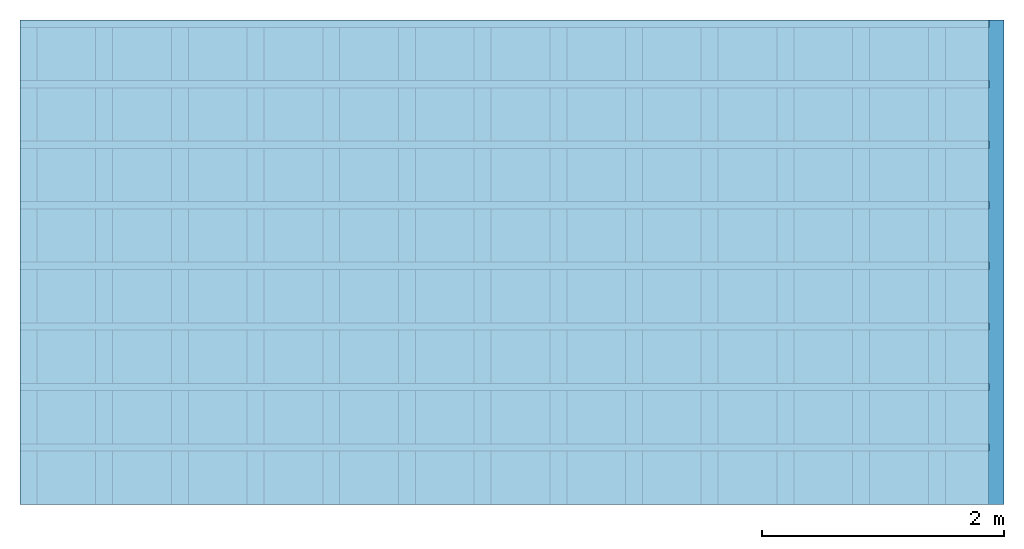
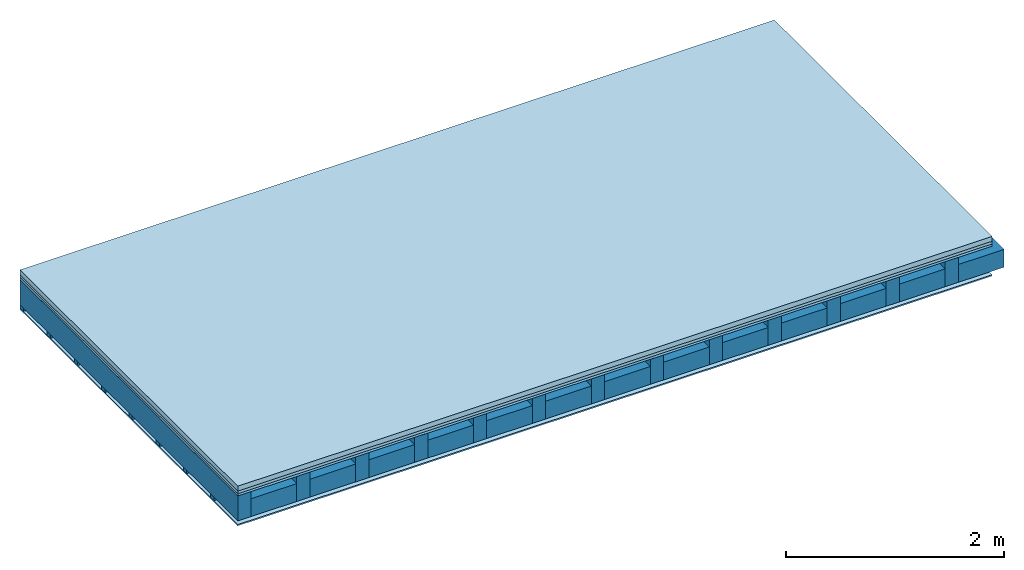
# One storey: 4 plates, 3 members, 1 element without a shape of its own.
"""IFC4 building model written with IfcOpenShell, lengths in metres."""

from ifc_helpers import new_model, si_unit, derived_unit, direction, frame, frame_2d, origin, origin_with_axes, place, context, project, spatial, rectangle, extrude, material, layer, layer_set, type_object, element, aggregate, save


model = new_model("IFC4")

# Units and contexts
plan_context = context("Plan", 3, precision=1e-05, world=origin(), true_north=direction((0.0, 1.0)))
model_context = context("Model", 3, precision=1e-05, world=origin(), true_north=direction((0.0, 1.0)))
ifc_project = project(units=[si_unit("LENGTHUNIT", "METRE"), derived_unit("SOUNDPRESSUREUNIT", [(si_unit("PRESSUREUNIT", "PASCAL", prefix="MICRO"), 0)]), si_unit("ENERGYUNIT", "JOULE", prefix="MEGA"), si_unit("MASSUNIT", "GRAM", prefix="KILO"), derived_unit("THERMALTRANSMITTANCEUNIT", [(si_unit("POWERUNIT", "WATT"), 1), (si_unit("AREAUNIT", "SQUARE_METRE"), -1), (si_unit("THERMODYNAMICTEMPERATUREUNIT", "KELVIN"), -1)]), derived_unit("AREADENSITYUNIT", [(si_unit("MASSUNIT", "GRAM", prefix="KILO"), 1), (si_unit("AREAUNIT", "SQUARE_METRE"), -1)]), derived_unit("USERDEFINED", [(si_unit("ENERGYUNIT", "JOULE", prefix="MEGA"), 1), (si_unit("AREAUNIT", "SQUARE_METRE"), -1)])], contexts=[plan_context, model_context])

# Site, building, storey
site = spatial("IfcSite", under=ifc_project)
building_placement = place(None, origin())
building = spatial("IfcBuilding", under=site, at=building_placement)
storey_placement = place(building_placement, origin())
storey = spatial("IfcBuildingStorey", under=building, at=storey_placement)

# Slab, members, plates
ifc_material_1 = material(Category="04.005")
ifc_layer_1 = layer(ifc_material_1, 0.055, Name="On-material")
ifc_material_2 = material()
ifc_layer_2 = layer(ifc_material_2, 0.03, Name="Impact sound insulation")
ifc_material_3 = material(Category="07.001")
ifc_layer_3 = layer(ifc_material_3, 0.025, Name="Sub-floor")
ifc_material_4 = material(Name="of the art")
ifc_layer_4 = layer(ifc_material_4, 0.0, Name="Bond")
ifc_layer_5 = layer(None, 0.28, Name="Supporting structure")
ifc_layer_6 = layer(ifc_material_4, 0.0, Name="Bond")
ifc_layer_7 = layer(None, 0.04, Name="Battens / profiles")
ifc_material_5 = material(Category="03.007")
ifc_layer_8 = layer(ifc_material_5, 0.015, Name="Ceiling covering 1st layer")
ifc_material_6 = material(Name="Glued joints")
ifc_layer_9 = layer(ifc_material_6, 0.0, Name="Surface / treatment")
ifc_layer_set = layer_set([ifc_layer_1, ifc_layer_2, ifc_layer_3, ifc_layer_4, ifc_layer_5, ifc_layer_6, ifc_layer_7, ifc_layer_8, ifc_layer_9])
slab_type = type_object("IfcSlabType", Name="A0107", PredefinedType="NOTDEFINED", material=ifc_layer_set)
slab_placement = place(None, frame((0.0, 0.0, 0.0), z_axis=(0.0, 0.0, -1.0), x_axis=(1.0, 0.0, 0.0)))
slab = element("IfcSlab", 1, at=slab_placement, inside=storey, type_object=slab_type, material=ifc_layer_set, Name="Slab #1")
ifc_material_7 = material()
member_1_placement = place(slab_placement, origin())
member_1 = element("IfcMember", 2, at=member_1_placement, material=ifc_material_7, Name="Supporting structure", context=plan_context, shape_type="SweptSolid", body=[
    extrude(rectangle(XDim=0.14, YDim=0.28, at=frame_2d((0.07, 0.14), x_axis=(1.0, 0.0))), frame((0.0, 4.0, 0.11), z_axis=(0.0, -1.0, 0.0), x_axis=(1.0, 0.0, 0.0)), (0.0, 0.0, 1.0), 4.0),
    extrude(rectangle(XDim=0.14, YDim=0.28, at=frame_2d((0.07, 0.14), x_axis=(1.0, 0.0))), frame((0.625, 4.0, 0.11), z_axis=(0.0, -1.0, 0.0), x_axis=(1.0, 0.0, 0.0)), (0.0, 0.0, 1.0), 4.0),
    extrude(rectangle(XDim=0.14, YDim=0.28, at=frame_2d((0.07, 0.14), x_axis=(1.0, 0.0))), frame((1.25, 4.0, 0.11), z_axis=(0.0, -1.0, 0.0), x_axis=(1.0, 0.0, 0.0)), (0.0, 0.0, 1.0), 4.0),
    extrude(rectangle(XDim=0.14, YDim=0.28, at=frame_2d((0.07, 0.14), x_axis=(1.0, 0.0))), frame((1.875, 4.0, 0.11), z_axis=(0.0, -1.0, 0.0), x_axis=(1.0, 0.0, 0.0)), (0.0, 0.0, 1.0), 4.0),
    extrude(rectangle(XDim=0.14, YDim=0.28, at=frame_2d((0.07, 0.14), x_axis=(1.0, 0.0))), frame((2.5, 4.0, 0.11), z_axis=(0.0, -1.0, 0.0), x_axis=(1.0, 0.0, 0.0)), (0.0, 0.0, 1.0), 4.0),
    extrude(rectangle(XDim=0.14, YDim=0.28, at=frame_2d((0.07, 0.14), x_axis=(1.0, 0.0))), frame((3.125, 4.0, 0.11), z_axis=(0.0, -1.0, 0.0), x_axis=(1.0, 0.0, 0.0)), (0.0, 0.0, 1.0), 4.0),
    extrude(rectangle(XDim=0.14, YDim=0.28, at=frame_2d((0.07, 0.14), x_axis=(1.0, 0.0))), frame((3.75, 4.0, 0.11), z_axis=(0.0, -1.0, 0.0), x_axis=(1.0, 0.0, 0.0)), (0.0, 0.0, 1.0), 4.0),
    extrude(rectangle(XDim=0.14, YDim=0.28, at=frame_2d((0.07, 0.14), x_axis=(1.0, 0.0))), frame((4.375, 4.0, 0.11), z_axis=(0.0, -1.0, 0.0), x_axis=(1.0, 0.0, 0.0)), (0.0, 0.0, 1.0), 4.0),
    extrude(rectangle(XDim=0.14, YDim=0.28, at=frame_2d((0.07, 0.14), x_axis=(1.0, 0.0))), frame((5.0, 4.0, 0.11), z_axis=(0.0, -1.0, 0.0), x_axis=(1.0, 0.0, 0.0)), (0.0, 0.0, 1.0), 4.0),
    extrude(rectangle(XDim=0.14, YDim=0.28, at=frame_2d((0.07, 0.14), x_axis=(1.0, 0.0))), frame((5.625, 4.0, 0.11), z_axis=(0.0, -1.0, 0.0), x_axis=(1.0, 0.0, 0.0)), (0.0, 0.0, 1.0), 4.0),
    extrude(rectangle(XDim=0.14, YDim=0.28, at=frame_2d((0.07, 0.14), x_axis=(1.0, 0.0))), frame((6.25, 4.0, 0.11), z_axis=(0.0, -1.0, 0.0), x_axis=(1.0, 0.0, 0.0)), (0.0, 0.0, 1.0), 4.0),
    extrude(rectangle(XDim=0.14, YDim=0.28, at=frame_2d((0.07, 0.14), x_axis=(1.0, 0.0))), frame((6.875, 4.0, 0.11), z_axis=(0.0, -1.0, 0.0), x_axis=(1.0, 0.0, 0.0)), (0.0, 0.0, 1.0), 4.0),
    extrude(rectangle(XDim=0.14, YDim=0.28, at=frame_2d((0.07, 0.14), x_axis=(1.0, 0.0))), frame((7.5, 4.0, 0.11), z_axis=(0.0, -1.0, 0.0), x_axis=(1.0, 0.0, 0.0)), (0.0, 0.0, 1.0), 4.0),
])
ifc_material_8 = material()
member_2_placement = place(slab_placement, origin())
member_2 = element("IfcMember", 3, at=member_2_placement, material=ifc_material_8, Name="Cavity", context=plan_context, shape_type="SweptSolid", body=[
    extrude(rectangle(XDim=0.485, YDim=0.2, at=frame_2d((0.2425, 0.1), x_axis=(1.0, 0.0))), frame((0.14, 4.0, 0.19), z_axis=(0.0, -1.0, 0.0), x_axis=(1.0, 0.0, 0.0)), (0.0, 0.0, 1.0), 4.0),
    extrude(rectangle(XDim=0.485, YDim=0.2, at=frame_2d((0.2425, 0.1), x_axis=(1.0, 0.0))), frame((0.765, 4.0, 0.19), z_axis=(0.0, -1.0, 0.0), x_axis=(1.0, 0.0, 0.0)), (0.0, 0.0, 1.0), 4.0),
    extrude(rectangle(XDim=0.485, YDim=0.2, at=frame_2d((0.2425, 0.1), x_axis=(1.0, 0.0))), frame((1.39, 4.0, 0.19), z_axis=(0.0, -1.0, 0.0), x_axis=(1.0, 0.0, 0.0)), (0.0, 0.0, 1.0), 4.0),
    extrude(rectangle(XDim=0.485, YDim=0.2, at=frame_2d((0.2425, 0.1), x_axis=(1.0, 0.0))), frame((2.015, 4.0, 0.19), z_axis=(0.0, -1.0, 0.0), x_axis=(1.0, 0.0, 0.0)), (0.0, 0.0, 1.0), 4.0),
    extrude(rectangle(XDim=0.485, YDim=0.2, at=frame_2d((0.2425, 0.1), x_axis=(1.0, 0.0))), frame((2.64, 4.0, 0.19), z_axis=(0.0, -1.0, 0.0), x_axis=(1.0, 0.0, 0.0)), (0.0, 0.0, 1.0), 4.0),
    extrude(rectangle(XDim=0.485, YDim=0.2, at=frame_2d((0.2425, 0.1), x_axis=(1.0, 0.0))), frame((3.265, 4.0, 0.19), z_axis=(0.0, -1.0, 0.0), x_axis=(1.0, 0.0, 0.0)), (0.0, 0.0, 1.0), 4.0),
    extrude(rectangle(XDim=0.485, YDim=0.2, at=frame_2d((0.2425, 0.1), x_axis=(1.0, 0.0))), frame((3.89, 4.0, 0.19), z_axis=(0.0, -1.0, 0.0), x_axis=(1.0, 0.0, 0.0)), (0.0, 0.0, 1.0), 4.0),
    extrude(rectangle(XDim=0.485, YDim=0.2, at=frame_2d((0.2425, 0.1), x_axis=(1.0, 0.0))), frame((4.515, 4.0, 0.19), z_axis=(0.0, -1.0, 0.0), x_axis=(1.0, 0.0, 0.0)), (0.0, 0.0, 1.0), 4.0),
    extrude(rectangle(XDim=0.485, YDim=0.2, at=frame_2d((0.2425, 0.1), x_axis=(1.0, 0.0))), frame((5.14, 4.0, 0.19), z_axis=(0.0, -1.0, 0.0), x_axis=(1.0, 0.0, 0.0)), (0.0, 0.0, 1.0), 4.0),
    extrude(rectangle(XDim=0.485, YDim=0.2, at=frame_2d((0.2425, 0.1), x_axis=(1.0, 0.0))), frame((5.765, 4.0, 0.19), z_axis=(0.0, -1.0, 0.0), x_axis=(1.0, 0.0, 0.0)), (0.0, 0.0, 1.0), 4.0),
    extrude(rectangle(XDim=0.485, YDim=0.2, at=frame_2d((0.2425, 0.1), x_axis=(1.0, 0.0))), frame((6.39, 4.0, 0.19), z_axis=(0.0, -1.0, 0.0), x_axis=(1.0, 0.0, 0.0)), (0.0, 0.0, 1.0), 4.0),
    extrude(rectangle(XDim=0.485, YDim=0.2, at=frame_2d((0.2425, 0.1), x_axis=(1.0, 0.0))), frame((7.015, 4.0, 0.19), z_axis=(0.0, -1.0, 0.0), x_axis=(1.0, 0.0, 0.0)), (0.0, 0.0, 1.0), 4.0),
    extrude(rectangle(XDim=0.485, YDim=0.2, at=frame_2d((0.2425, 0.1), x_axis=(1.0, 0.0))), frame((7.64, 4.0, 0.19), z_axis=(0.0, -1.0, 0.0), x_axis=(1.0, 0.0, 0.0)), (0.0, 0.0, 1.0), 4.0),
])
ifc_material_9 = material()
member_3_placement = place(slab_placement, origin())
member_3 = element("IfcMember", 4, at=member_3_placement, material=ifc_material_9, Name="Battens / profiles", context=plan_context, shape_type="SweptSolid", body=[
    extrude(rectangle(XDim=0.06, YDim=0.04, at=frame_2d((0.03, 0.02), x_axis=(1.0, 0.0))), frame((0.0, 0.0, 0.39), z_axis=(1.0, 0.0, 0.0), x_axis=(0.0, 1.0, 0.0)), (0.0, 0.0, 1.0), 8.0),
    extrude(rectangle(XDim=0.06, YDim=0.04, at=frame_2d((0.03, 0.02), x_axis=(1.0, 0.0))), frame((0.0, 0.5, 0.39), z_axis=(1.0, 0.0, 0.0), x_axis=(0.0, 1.0, 0.0)), (0.0, 0.0, 1.0), 8.0),
    extrude(rectangle(XDim=0.06, YDim=0.04, at=frame_2d((0.03, 0.02), x_axis=(1.0, 0.0))), frame((0.0, 1.0, 0.39), z_axis=(1.0, 0.0, 0.0), x_axis=(0.0, 1.0, 0.0)), (0.0, 0.0, 1.0), 8.0),
    extrude(rectangle(XDim=0.06, YDim=0.04, at=frame_2d((0.03, 0.02), x_axis=(1.0, 0.0))), frame((0.0, 1.5, 0.39), z_axis=(1.0, 0.0, 0.0), x_axis=(0.0, 1.0, 0.0)), (0.0, 0.0, 1.0), 8.0),
    extrude(rectangle(XDim=0.06, YDim=0.04, at=frame_2d((0.03, 0.02), x_axis=(1.0, 0.0))), frame((0.0, 2.0, 0.39), z_axis=(1.0, 0.0, 0.0), x_axis=(0.0, 1.0, 0.0)), (0.0, 0.0, 1.0), 8.0),
    extrude(rectangle(XDim=0.06, YDim=0.04, at=frame_2d((0.03, 0.02), x_axis=(1.0, 0.0))), frame((0.0, 2.5, 0.39), z_axis=(1.0, 0.0, 0.0), x_axis=(0.0, 1.0, 0.0)), (0.0, 0.0, 1.0), 8.0),
    extrude(rectangle(XDim=0.06, YDim=0.04, at=frame_2d((0.03, 0.02), x_axis=(1.0, 0.0))), frame((0.0, 3.0, 0.39), z_axis=(1.0, 0.0, 0.0), x_axis=(0.0, 1.0, 0.0)), (0.0, 0.0, 1.0), 8.0),
    extrude(rectangle(XDim=0.06, YDim=0.04, at=frame_2d((0.03, 0.02), x_axis=(1.0, 0.0))), frame((0.0, 3.5, 0.39), z_axis=(1.0, 0.0, 0.0), x_axis=(0.0, 1.0, 0.0)), (0.0, 0.0, 1.0), 8.0),
])
plate_1_placement = place(slab_placement, origin())
plate_1 = element("IfcPlate", 5, at=plate_1_placement, material=ifc_material_1, Name="On-material", context=plan_context, shape_type="SweptSolid", body=[
    extrude(rectangle(XDim=8.0, YDim=4.0, at=frame_2d((4.0, 2.0), x_axis=(1.0, 0.0))), origin_with_axes(), (0.0, 0.0, 1.0), 0.055),
])
plate_2_placement = place(slab_placement, origin())
plate_2 = element("IfcPlate", 6, at=plate_2_placement, material=ifc_material_2, Name="Impact sound insulation", context=plan_context, shape_type="SweptSolid", body=[
    extrude(rectangle(XDim=8.0, YDim=4.0, at=frame_2d((4.0, 2.0), x_axis=(1.0, 0.0))), frame((0.0, 0.0, 0.055), z_axis=(0.0, 0.0, 1.0), x_axis=(1.0, 0.0, 0.0)), (0.0, 0.0, 1.0), 0.03),
])
plate_3_placement = place(slab_placement, origin())
plate_3 = element("IfcPlate", 7, at=plate_3_placement, material=ifc_material_3, Name="Sub-floor", context=plan_context, shape_type="SweptSolid", body=[
    extrude(rectangle(XDim=8.0, YDim=4.0, at=frame_2d((4.0, 2.0), x_axis=(1.0, 0.0))), frame((0.0, 0.0, 0.085), z_axis=(0.0, 0.0, 1.0), x_axis=(1.0, 0.0, 0.0)), (0.0, 0.0, 1.0), 0.025),
])
plate_4_placement = place(slab_placement, origin())
plate_4 = element("IfcPlate", 8, at=plate_4_placement, material=ifc_material_5, Name="Ceiling covering 1st layer", context=plan_context, shape_type="SweptSolid", body=[
    extrude(rectangle(XDim=8.0, YDim=4.0, at=frame_2d((4.0, 2.0), x_axis=(1.0, 0.0))), frame((0.0, 0.0, 0.43), z_axis=(0.0, 0.0, 1.0), x_axis=(1.0, 0.0, 0.0)), (0.0, 0.0, 1.0), 0.015),
])
aggregate(slab, [plate_1, plate_2, plate_3, member_1, member_2, member_3, plate_4])

save(model, "model.ifc")
